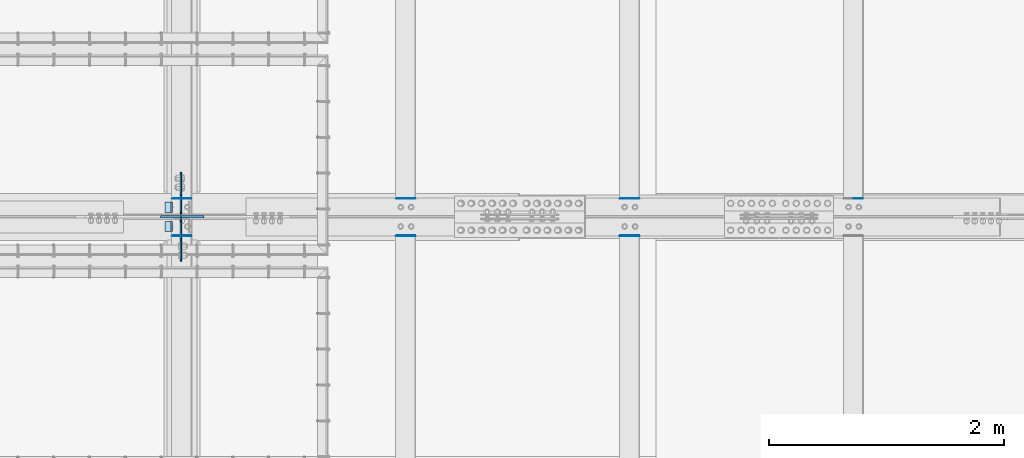
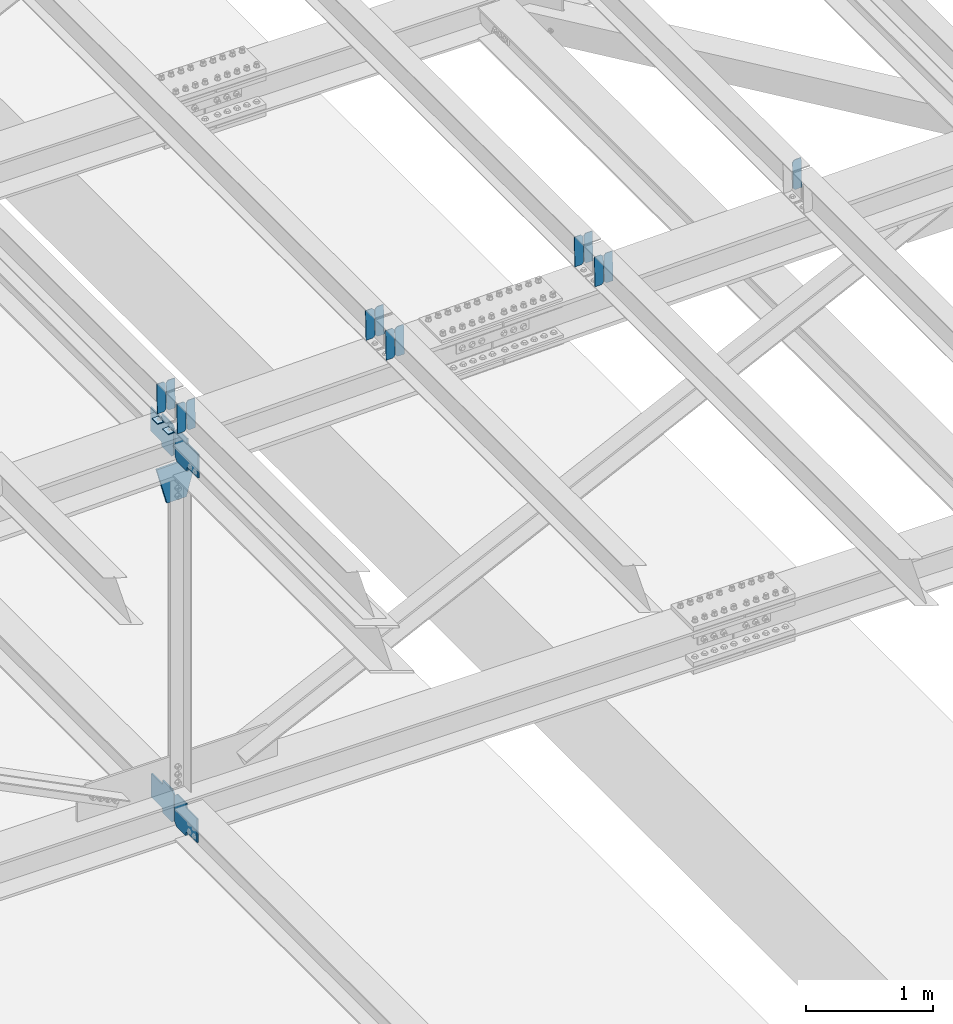
# One storey, part 3317 of 3843: 20 plates, 9 elements without a shape of their own.
"""IFC2X3 building model written with IfcOpenShell, lengths in millimetres."""

from ifc_helpers import new_model, si_unit, frame, origin_with_axes, place, context, subcontext, project, spatial, faceted_brep, material, type_object, element, aggregate, save


model = new_model("IFC2X3")

# Units and contexts
model_context = context("Model", 3, precision=1e-05, world=origin_with_axes())
body_context = subcontext(model_context, "Body", "Model", "MODEL_VIEW")
ifc_project = project(units=[si_unit("LENGTHUNIT", "METRE", prefix="MILLI"), si_unit("AREAUNIT", "SQUARE_METRE"), si_unit("VOLUMEUNIT", "CUBIC_METRE"), si_unit("MASSUNIT", "GRAM", prefix="KILO"), si_unit("TIMEUNIT", "SECOND"), si_unit("PLANEANGLEUNIT", "RADIAN"), si_unit("SOLIDANGLEUNIT", "STERADIAN"), si_unit("THERMODYNAMICTEMPERATUREUNIT", "DEGREE_CELSIUS"), si_unit("LUMINOUSINTENSITYUNIT", "LUMEN")], contexts=[model_context])

# Site, building, storey
site_placement = place(None, origin_with_axes())
site = spatial("IfcSite", under=ifc_project, at=site_placement, CompositionType="ELEMENT")
building_placement = place(site_placement, origin_with_axes())
building = spatial("IfcBuilding", under=site, at=building_placement, Name="Undefined", CompositionType="ELEMENT")
storey_placement = place(building_placement, origin_with_axes())
storey = spatial("IfcBuildingStorey", under=building, at=storey_placement, Name="Undefined", CompositionType="ELEMENT", Elevation=0.0)

# Assembly, plates
assembly_1_placement = place(storey_placement, origin_with_axes())
assembly_1 = element("IfcElementAssembly", 1, at=assembly_1_placement, inside=storey, Name="BEAM", AssemblyPlace="NOTDEFINED", PredefinedType="RIGID_FRAME")
ifc_material = material(Name="STEEL/A572-50")
plate_type_1 = type_object("IfcPlateType", PredefinedType="NOTDEFINED")
plate_1_placement = place(assembly_1_placement, frame((62718.6964783432, 59070.762745456, 46080.1519820071), z_axis=(-0.0211520975052917, 0.000376250999834155, 0.999776198559614), x_axis=(-0.9997762693548, -8.33599996866193e-06, -0.0211520960075009)))
plate_1 = element("IfcPlate", 2, at=plate_1_placement, type_object=plate_type_1, material=ifc_material, Name="PLATE", context=body_context, shape_type="Brep", body=[
    faceted_brep([(0.0, -3.17499999999927, 0.0), (6.83940015733242e-10, -3.17499999996653, 288.924999998613), (6.54836185276508e-10, 3.17500000001746, 288.924999998591), (0.0, 3.17499999999927, 0.0), (60.3250007643655, -3.17500000017753, 288.924999998606), (60.3250007643219, 3.17499999979918, 288.924999998584), (79.3750000013097, -3.17500000025029, 269.875000761494), (79.375000001266, 3.17499999972642, 269.875000761487), (79.375000000713, -3.17500000026484, 19.0499992370605), (79.3750000006985, 3.17499999971187, 19.0499992370533), (60.325000763667, -3.17500000020664, -1.45519152283669e-11), (60.3250007636234, 3.17499999977736, -3.63797880709171e-11)], [[[0, 1, 2, 3]], [[1, 4, 5, 2]], [[4, 6, 7, 5]], [[6, 8, 9, 7]], [[8, 10, 11, 9]], [[10, 0, 3, 11]], [[5, 7, 9, 11, 3, 2]], [[10, 8, 6, 4, 1, 0]]]),
])
plate_2_placement = place(assembly_1_placement, frame((62632.9906576536, 59070.7620630619, 46078.3387185351), z_axis=(-0.0211520975052917, 0.000376250999834155, 0.999776198559614), x_axis=(-0.9997762693548, -8.33599996866193e-06, -0.0211520960075009)))
plate_2 = element("IfcPlate", 3, at=plate_2_placement, type_object=plate_type_1, material=ifc_material, Name="PLATE", context=body_context, shape_type="Brep", body=[
    faceted_brep([(4.36557456851006e-11, -3.17499999998836, 19.0499992370969), (6.11180439591408e-10, -3.17499999996653, 269.875000761516), (5.96628524363041e-10, 3.17500000001746, 269.875000761502), (1.45519152283669e-11, 3.17499999998836, 19.0499992370824), (19.0499992376572, -3.17500000003201, 288.924999998606), (19.0499992376281, 3.1749999999447, 288.924999998584), (79.3750000013242, -3.17500000025029, 288.924999998591), (79.3750000013097, 3.1749999997337, 288.92499999857), (79.3750000006548, -3.17500000026484, -2.18278728425503e-11), (79.3750000006403, 3.17499999969732, -2.91038304567337e-11), (19.0499992370023, -3.17500000005384, 0.0), (19.0499992369587, 3.17499999992287, -1.45519152283669e-11)], [[[0, 1, 2, 3]], [[1, 4, 5, 2]], [[4, 6, 7, 5]], [[6, 8, 9, 7]], [[8, 10, 11, 9]], [[10, 0, 3, 11]], [[5, 7, 9, 11, 3, 2]], [[10, 8, 6, 4, 1, 0]]]),
])

assembly_2_placement = place(storey_placement, origin_with_axes())
assembly_2 = element("IfcElementAssembly", 4, at=assembly_2_placement, inside=storey, Name="BEAM", AssemblyPlace="NOTDEFINED", PredefinedType="RIGID_FRAME")
plate_3_placement = place(assembly_2_placement, frame((62718.6964783118, 58753.4858396267, 46080.1503629439), z_axis=(-0.0211520984675226, -0.000371508000112954, 0.999776200312963), x_axis=(-0.999776269354799, 8.33600001439919e-06, -0.0211520960075334)))
plate_3 = element("IfcPlate", 5, at=plate_3_placement, type_object=plate_type_1, material=ifc_material, Name="PLATE", context=body_context, shape_type="Brep", body=[
    faceted_brep([(0.0, -3.17499999999927, 0.0), (6.83940015733242e-10, -3.17499999996653, 288.924999998613), (6.54836185276508e-10, 3.17500000001746, 288.924999998591), (0.0, 3.17499999999927, 0.0), (60.3250007643655, -3.17500000017753, 288.924999998606), (60.3250007643219, 3.17499999979918, 288.924999998584), (79.3750000013097, -3.17500000025029, 269.875000761494), (79.375000001266, 3.17499999972642, 269.875000761487), (79.375000000713, -3.17500000026484, 19.0499992370605), (79.3750000006985, 3.17499999971187, 19.0499992370533), (60.325000763667, -3.17500000020664, -1.45519152283669e-11), (60.3250007636234, 3.17499999977736, -3.63797880709171e-11)], [[[0, 1, 2, 3]], [[1, 4, 5, 2]], [[4, 6, 7, 5]], [[6, 8, 9, 7]], [[8, 10, 11, 9]], [[10, 0, 3, 11]], [[5, 7, 9, 11, 3, 2]], [[10, 8, 6, 4, 1, 0]]]),
])
plate_4_placement = place(assembly_2_placement, frame((62632.9906576221, 58753.4865134214, 46078.3370994677), z_axis=(-0.0211520984675226, -0.000371508000112954, 0.999776200312963), x_axis=(-0.999776269354799, 8.33600001439919e-06, -0.0211520960075334)))
plate_4 = element("IfcPlate", 6, at=plate_4_placement, type_object=plate_type_1, material=ifc_material, Name="PLATE", context=body_context, shape_type="Brep", body=[
    faceted_brep([(4.36557456851006e-11, -3.17499999998836, 19.0499992370969), (6.11180439591408e-10, -3.17499999996653, 269.875000761516), (5.96628524363041e-10, 3.17500000001746, 269.875000761502), (1.45519152283669e-11, 3.17499999998836, 19.0499992370824), (19.0499992376572, -3.17500000003201, 288.924999998606), (19.0499992376281, 3.1749999999447, 288.924999998584), (79.3750000013242, -3.17500000025029, 288.924999998591), (79.3750000013097, 3.1749999997337, 288.92499999857), (79.3750000006548, -3.17500000026484, -2.18278728425503e-11), (79.3750000006403, 3.17499999969732, -2.91038304567337e-11), (19.0499992370023, -3.17500000005384, 0.0), (19.0499992369587, 3.17499999992287, -1.45519152283669e-11)], [[[0, 1, 2, 3]], [[1, 4, 5, 2]], [[4, 6, 7, 5]], [[6, 8, 9, 7]], [[8, 10, 11, 9]], [[10, 0, 3, 11]], [[5, 7, 9, 11, 3, 2]], [[10, 8, 6, 4, 1, 0]]]),
])

# Assembly, plate
assembly_3_placement = place(storey_placement, origin_with_axes())
assembly_3 = element("IfcElementAssembly", 7, at=assembly_3_placement, inside=storey, Name="BEAM", AssemblyPlace="NOTDEFINED", PredefinedType="RIGID_FRAME")
plate_5_placement = place(assembly_3_placement, frame((68433.6964817623, 59070.741525051, 46205.0688517431), z_axis=(-0.0211520981150825, 0.000447354000119958, 0.999776169259764), x_axis=(-0.999776269336729, -1.02780000340977e-05, -0.0211520960071139)))
plate_5 = element("IfcPlate", 8, at=plate_5_placement, type_object=plate_type_1, material=ifc_material, Name="PLATE", context=body_context, shape_type="Brep", body=[
    faceted_brep([(0.0, -3.17499999999927, 0.0), (6.83940015733242e-10, -3.17499999996653, 288.924999998613), (6.54836185276508e-10, 3.17500000001746, 288.924999998591), (0.0, 3.17499999999927, 0.0), (60.3250007643655, -3.17500000017753, 288.924999998606), (60.3250007643219, 3.17499999979918, 288.924999998584), (79.3750000013097, -3.17500000025029, 269.875000761494), (79.375000001266, 3.17499999972642, 269.875000761487), (79.375000000713, -3.17500000026484, 19.0499992370605), (79.3750000006985, 3.17499999971187, 19.0499992370533), (60.325000763667, -3.17500000020664, -1.45519152283669e-11), (60.3250007636234, 3.17499999977736, -3.63797880709171e-11)], [[[0, 1, 2, 3]], [[1, 4, 5, 2]], [[4, 6, 7, 5]], [[6, 8, 9, 7]], [[8, 10, 11, 9]], [[10, 0, 3, 11]], [[5, 7, 9, 11, 3, 2]], [[10, 8, 6, 4, 1, 0]]]),
])
aggregate(assembly_3, [plate_5])

# Assembly, plates
assembly_4_placement = place(storey_placement, origin_with_axes())
assembly_4 = element("IfcElementAssembly", 9, at=assembly_4_placement, inside=storey, Name="BEAM", AssemblyPlace="NOTDEFINED", PredefinedType="RIGID_FRAME")
plate_6_placement = place(assembly_4_placement, frame((66528.6964817708, 59070.7498081989, 46164.0919429248), z_axis=(-0.0211520978608897, 0.000419598000124098, 0.999776181299395), x_axis=(-0.9997762693548, -8.33599996866193e-06, -0.0211520960075009)))
plate_6 = element("IfcPlate", 10, at=plate_6_placement, type_object=plate_type_1, material=ifc_material, Name="PLATE", context=body_context, shape_type="Brep", body=[
    faceted_brep([(0.0, -3.17499999999927, 0.0), (6.83940015733242e-10, -3.17499999996653, 288.924999998613), (6.54836185276508e-10, 3.17500000001746, 288.924999998591), (0.0, 3.17499999999927, 0.0), (60.3250007643655, -3.17500000017753, 288.924999998606), (60.3250007643219, 3.17499999979918, 288.924999998584), (79.3750000013097, -3.17500000025029, 269.875000761494), (79.375000001266, 3.17499999972642, 269.875000761487), (79.375000000713, -3.17500000026484, 19.0499992370605), (79.3750000006985, 3.17499999971187, 19.0499992370533), (60.325000763667, -3.17500000020664, -1.45519152283669e-11), (60.3250007636234, 3.17499999977736, -3.63797880709171e-11)], [[[0, 1, 2, 3]], [[1, 4, 5, 2]], [[4, 6, 7, 5]], [[6, 8, 9, 7]], [[8, 10, 11, 9]], [[10, 0, 3, 11]], [[5, 7, 9, 11, 3, 2]], [[10, 8, 6, 4, 1, 0]]]),
])
plate_7_placement = place(assembly_4_placement, frame((66442.9906610805, 59070.7490490722, 46162.2786794823), z_axis=(-0.0211520978608897, 0.000419598000124098, 0.999776181299395), x_axis=(-0.9997762693548, -8.33599996866193e-06, -0.0211520960075009)))
plate_7 = element("IfcPlate", 11, at=plate_7_placement, type_object=plate_type_1, material=ifc_material, Name="PLATE", context=body_context, shape_type="Brep", body=[
    faceted_brep([(4.36557456851006e-11, -3.17499999998836, 19.0499992370969), (6.11180439591408e-10, -3.17499999996653, 269.875000761516), (5.96628524363041e-10, 3.17500000001746, 269.875000761502), (1.45519152283669e-11, 3.17499999998836, 19.0499992370824), (19.0499992376572, -3.17500000003201, 288.924999998606), (19.0499992376281, 3.1749999999447, 288.924999998584), (79.3750000013242, -3.17500000025029, 288.924999998591), (79.3750000013097, 3.1749999997337, 288.92499999857), (79.3750000006548, -3.17500000026484, -2.18278728425503e-11), (79.3750000006403, 3.17499999969732, -2.91038304567337e-11), (19.0499992370023, -3.17500000005384, 0.0), (19.0499992369587, 3.17499999992287, -1.45519152283669e-11)], [[[0, 1, 2, 3]], [[1, 4, 5, 2]], [[4, 6, 7, 5]], [[6, 8, 9, 7]], [[8, 10, 11, 9]], [[10, 0, 3, 11]], [[5, 7, 9, 11, 3, 2]], [[10, 8, 6, 4, 1, 0]]]),
])
aggregate(assembly_4, [plate_6, plate_7])

assembly_5_placement = place(storey_placement, origin_with_axes())
assembly_5 = element("IfcElementAssembly", 12, at=assembly_5_placement, inside=storey, Name="BEAM", AssemblyPlace="NOTDEFINED", PredefinedType="RIGID_FRAME")
plate_8_placement = place(assembly_5_placement, frame((66528.6964783558, 58753.5020115444, 46164.0882872405), z_axis=(-0.0211520979246561, -0.000425699999883364, 0.999776178718465), x_axis=(-0.999776269351943, 8.67199997865676e-06, -0.0211520960074328)))
plate_8 = element("IfcPlate", 13, at=plate_8_placement, type_object=plate_type_1, material=ifc_material, Name="PLATE", context=body_context, shape_type="Brep", body=[
    faceted_brep([(0.0, -3.17499999999927, 0.0), (6.83940015733242e-10, -3.17499999996653, 288.924999998613), (6.54836185276508e-10, 3.17500000001746, 288.924999998591), (0.0, 3.17499999999927, 0.0), (60.3250007643655, -3.17500000017753, 288.924999998606), (60.3250007643219, 3.17499999979918, 288.924999998584), (79.3750000013097, -3.17500000025029, 269.875000761494), (79.375000001266, 3.17499999972642, 269.875000761487), (79.375000000713, -3.17500000026484, 19.0499992370605), (79.3750000006985, 3.17499999971187, 19.0499992370533), (60.325000763667, -3.17500000020664, -1.45519152283669e-11), (60.3250007636234, 3.17499999977736, -3.63797880709171e-11)], [[[0, 1, 2, 3]], [[1, 4, 5, 2]], [[4, 6, 7, 5]], [[6, 8, 9, 7]], [[8, 10, 11, 9]], [[10, 0, 3, 11]], [[5, 7, 9, 11, 3, 2]], [[10, 8, 6, 4, 1, 0]]]),
])
plate_9_placement = place(assembly_5_placement, frame((66442.9906576646, 58753.5027836236, 46162.2750238046), z_axis=(-0.0211520979246561, -0.000425699999883364, 0.999776178718465), x_axis=(-0.999776269351943, 8.67199997865676e-06, -0.0211520960074328)))
plate_9 = element("IfcPlate", 14, at=plate_9_placement, type_object=plate_type_1, material=ifc_material, Name="PLATE", context=body_context, shape_type="Brep", body=[
    faceted_brep([(4.36557456851006e-11, -3.17499999998836, 19.0499992370969), (6.11180439591408e-10, -3.17499999996653, 269.875000761516), (5.96628524363041e-10, 3.17500000001746, 269.875000761502), (1.45519152283669e-11, 3.17499999998836, 19.0499992370824), (19.0499992376572, -3.17500000003201, 288.924999998606), (19.0499992376281, 3.1749999999447, 288.924999998584), (79.3750000013242, -3.17500000025029, 288.924999998591), (79.3750000013097, 3.1749999997337, 288.92499999857), (79.3750000006548, -3.17500000026484, -2.18278728425503e-11), (79.3750000006403, 3.17499999969732, -2.91038304567337e-11), (19.0499992370023, -3.17500000005384, 0.0), (19.0499992369587, 3.17499999992287, -1.45519152283669e-11)], [[[0, 1, 2, 3]], [[1, 4, 5, 2]], [[4, 6, 7, 5]], [[6, 8, 9, 7]], [[8, 10, 11, 9]], [[10, 0, 3, 11]], [[5, 7, 9, 11, 3, 2]], [[10, 8, 6, 4, 1, 0]]]),
])
aggregate(assembly_5, [plate_8, plate_9])

assembly_6_placement = place(storey_placement, origin_with_axes())
assembly_6 = element("IfcElementAssembly", 15, at=assembly_6_placement, inside=storey, Name="BEAM", AssemblyPlace="NOTDEFINED", PredefinedType="RIGID_FRAME")
plate_10_placement = place(assembly_6_placement, frame((64623.696481784, 59070.7559547485, 46122.481967059), z_axis=(-0.0211520976833125, 0.000399000999888811, 0.999776189735382), x_axis=(-0.9997762693548, -8.33599996866193e-06, -0.0211520960075009)))
plate_10 = element("IfcPlate", 16, at=plate_10_placement, type_object=plate_type_1, material=ifc_material, Name="PLATE", context=body_context, shape_type="Brep", body=[
    faceted_brep([(0.0, -3.17499999999927, 0.0), (6.83940015733242e-10, -3.17499999996653, 288.924999998613), (6.54836185276508e-10, 3.17500000001746, 288.924999998591), (0.0, 3.17499999999927, 0.0), (60.3250007643655, -3.17500000017753, 288.924999998606), (60.3250007643219, 3.17499999979918, 288.924999998584), (79.3750000013097, -3.17500000025029, 269.875000761494), (79.375000001266, 3.17499999972642, 269.875000761487), (79.375000000713, -3.17500000026484, 19.0499992370605), (79.3750000006985, 3.17499999971187, 19.0499992370533), (60.325000763667, -3.17500000020664, -1.45519152283669e-11), (60.3250007636234, 3.17499999977736, -3.63797880709171e-11)], [[[0, 1, 2, 3]], [[1, 4, 5, 2]], [[4, 6, 7, 5]], [[6, 8, 9, 7]], [[8, 10, 11, 9]], [[10, 0, 3, 11]], [[5, 7, 9, 11, 3, 2]], [[10, 8, 6, 4, 1, 0]]]),
])
plate_11_placement = place(assembly_6_placement, frame((64537.9906610943, 59070.7552329783, 46120.6687036018), z_axis=(-0.0211520976833125, 0.000399000999888811, 0.999776189735382), x_axis=(-0.9997762693548, -8.33599996866193e-06, -0.0211520960075009)))
plate_11 = element("IfcPlate", 17, at=plate_11_placement, type_object=plate_type_1, material=ifc_material, Name="PLATE", context=body_context, shape_type="Brep", body=[
    faceted_brep([(4.36557456851006e-11, -3.17499999998836, 19.0499992370969), (6.11180439591408e-10, -3.17499999996653, 269.875000761516), (5.96628524363041e-10, 3.17500000001746, 269.875000761502), (1.45519152283669e-11, 3.17499999998836, 19.0499992370824), (19.0499992376572, -3.17500000003201, 288.924999998606), (19.0499992376281, 3.1749999999447, 288.924999998584), (79.3750000013242, -3.17500000025029, 288.924999998591), (79.3750000013097, 3.1749999997337, 288.92499999857), (79.3750000006548, -3.17500000026484, -2.18278728425503e-11), (79.3750000006403, 3.17499999969732, -2.91038304567337e-11), (19.0499992370023, -3.17500000005384, 0.0), (19.0499992369587, 3.17499999992287, -1.45519152283669e-11)], [[[0, 1, 2, 3]], [[1, 4, 5, 2]], [[4, 6, 7, 5]], [[6, 8, 9, 7]], [[8, 10, 11, 9]], [[10, 0, 3, 11]], [[5, 7, 9, 11, 3, 2]], [[10, 8, 6, 4, 1, 0]]]),
])
aggregate(assembly_6, [plate_10, plate_11])

assembly_7_placement = place(storey_placement, origin_with_axes())
assembly_7 = element("IfcElementAssembly", 18, at=assembly_7_placement, inside=storey, Name="BEAM", AssemblyPlace="NOTDEFINED", PredefinedType="RIGID_FRAME")
plate_12_placement = place(assembly_7_placement, frame((64623.696478336, 58753.49392905, 46122.4794956833), z_axis=(-0.021152097688544, -0.000398615999954926, 0.999776189888847), x_axis=(-0.999776269351943, 8.67199997865676e-06, -0.0211520960074328)))
plate_12 = element("IfcPlate", 19, at=plate_12_placement, type_object=plate_type_1, material=ifc_material, Name="PLATE", context=body_context, shape_type="Brep", body=[
    faceted_brep([(0.0, -3.17499999999927, 0.0), (6.83940015733242e-10, -3.17499999996653, 288.924999998613), (6.54836185276508e-10, 3.17500000001746, 288.924999998591), (0.0, 3.17499999999927, 0.0), (60.3250007643655, -3.17500000017753, 288.924999998606), (60.3250007643219, 3.17499999979918, 288.924999998584), (79.3750000013097, -3.17500000025029, 269.875000761494), (79.375000001266, 3.17499999972642, 269.875000761487), (79.375000000713, -3.17500000026484, 19.0499992370605), (79.3750000006985, 3.17499999971187, 19.0499992370533), (60.325000763667, -3.17500000020664, -1.45519152283669e-11), (60.3250007636234, 3.17499999977736, -3.63797880709171e-11)], [[[0, 1, 2, 3]], [[1, 4, 5, 2]], [[4, 6, 7, 5]], [[6, 8, 9, 7]], [[8, 10, 11, 9]], [[10, 0, 3, 11]], [[5, 7, 9, 11, 3, 2]], [[10, 8, 6, 4, 1, 0]]]),
])
plate_13_placement = place(assembly_7_placement, frame((64537.9906576466, 58753.4946520073, 46120.6662322268), z_axis=(-0.021152097688544, -0.000398615999954926, 0.999776189888847), x_axis=(-0.999776269351943, 8.67199997865676e-06, -0.0211520960074328)))
plate_13 = element("IfcPlate", 20, at=plate_13_placement, type_object=plate_type_1, material=ifc_material, Name="PLATE", context=body_context, shape_type="Brep", body=[
    faceted_brep([(4.36557456851006e-11, -3.17499999998836, 19.0499992370969), (6.11180439591408e-10, -3.17499999996653, 269.875000761516), (5.96628524363041e-10, 3.17500000001746, 269.875000761502), (1.45519152283669e-11, 3.17499999998836, 19.0499992370824), (19.0499992376572, -3.17500000003201, 288.924999998606), (19.0499992376281, 3.1749999999447, 288.924999998584), (79.3750000013242, -3.17500000025029, 288.924999998591), (79.3750000013097, 3.1749999997337, 288.92499999857), (79.3750000006548, -3.17500000026484, -2.18278728425503e-11), (79.3750000006403, 3.17499999969732, -2.91038304567337e-11), (19.0499992370023, -3.17500000005384, 0.0), (19.0499992369587, 3.17499999992287, -1.45519152283669e-11)], [[[0, 1, 2, 3]], [[1, 4, 5, 2]], [[4, 6, 7, 5]], [[6, 8, 9, 7]], [[8, 10, 11, 9]], [[10, 0, 3, 11]], [[5, 7, 9, 11, 3, 2]], [[10, 8, 6, 4, 1, 0]]]),
])
aggregate(assembly_7, [plate_12, plate_13])

# Plate
plate_type_2 = type_object("IfcPlateType", PredefinedType="NOTDEFINED")
plate_14_placement = place(assembly_1_placement, frame((62553.767731786, 59042.3, 46070.3697076581), z_axis=(0.0, -1.0, 0.0), x_axis=(-0.999776270257024, 0.0, -0.0211520550054595)))
plate_14 = element("IfcPlate", 21, at=plate_14_placement, type_object=plate_type_2, material=ifc_material, Name="PLATE", context=body_context, shape_type="Brep", body=[
    faceted_brep([(9.52499999982683, -4.7625000001135, 88.8999999999942), (0.0, 4.76249999999709, 88.9000015258789), (0.0, 4.76249999999709, 0.0), (9.52499999981956, -4.76249999999709, 0.0), (63.4999984608512, -4.76249999988795, 88.8999999999796), (63.4999984608367, -4.76249999988795, -1.45519152283669e-11), (63.4999984608221, 4.76250000013533, -1.45519152283669e-11), (63.4999984608367, 4.76250000013533, 88.8999999999796)], [[[0, 1, 2, 3]], [[4, 5, 6, 7]], [[5, 4, 0, 3]], [[6, 5, 3, 2]], [[7, 6, 2, 1]], [[4, 7, 1, 0]]]),
])

aggregate(assembly_1, [plate_1, plate_2, plate_14])

plate_15_placement = place(assembly_2_placement, frame((62553.767731786, 58877.2000015258, 46070.3697076581), z_axis=(0.0, -1.0, 0.0), x_axis=(-0.999776270257024, 0.0, -0.0211520550054595)))
plate_15 = element("IfcPlate", 22, at=plate_15_placement, type_object=plate_type_2, material=ifc_material, Name="PLATE", context=body_context, shape_type="Brep", body=[
    faceted_brep([(9.52499999982683, -4.7625000001135, 88.8999999999942), (0.0, 4.76249999999709, 88.9000015258789), (0.0, 4.76249999999709, 0.0), (9.52499999981956, -4.76249999999709, 0.0), (63.4999984608512, -4.76249999988795, 88.8999999999796), (63.4999984608367, -4.76249999988795, -1.45519152283669e-11), (63.4999984608221, 4.76250000013533, -1.45519152283669e-11), (63.4999984608367, 4.76250000013533, 88.8999999999796)], [[[0, 1, 2, 3]], [[4, 5, 6, 7]], [[5, 4, 0, 3]], [[6, 5, 3, 2]], [[7, 6, 2, 1]], [[4, 7, 1, 0]]]),
])

aggregate(assembly_2, [plate_3, plate_4, plate_15])

# Assembly, plates
assembly_8_placement = place(storey_placement, origin_with_axes())
assembly_8 = element("IfcElementAssembly", 23, at=assembly_8_placement, inside=storey, Name="BEAM", AssemblyPlace="NOTDEFINED", PredefinedType="RIGID_FRAME")
plate_type_3 = type_object("IfcPlateType", PredefinedType="NOTDEFINED")
plate_16_placement = place(assembly_8_placement, frame((62625.2874999719, 58922.44375, 42217.0959217908), z_axis=(0.0, 0.707106781186548, 0.707106781186548), x_axis=(5.70000238222118e-08, 0.707106781186546, -0.707106781186546)))
plate_16 = element("IfcPlate", 24, at=plate_16_placement, type_object=plate_type_3, material=ifc_material, Name="PLATE", context=body_context, shape_type="Brep", body=[
    faceted_brep([(0.0, -6.3499999046162, 0.0), (-179.593979054845, -6.34999999999854, 179.593979055615), (-179.593979054845, 6.34999999999854, 179.593979055615), (7.27595761418343e-12, 6.3499999046162, 0.0), (-179.59397905474, -6.34999999999854, 224.49525966098), (-179.59397905474, 6.34999999999854, 224.49525966098), (-75.7597676884743, -6.34999999999854, 328.329471026809), (-75.7597676884743, 6.34999999999854, 328.329471026809), (-53.261477843118, -6.34999999999854, 305.831181181362), (-53.261477843118, 6.34999999999854, 305.831181181362), (-49.1413013749861, -6.34999999999854, 303.078167280881), (-49.1413013749861, 6.34999999999854, 303.078167280881), (-44.2812218569543, -6.34999999999854, 302.111437358297), (-44.2812218569543, 6.34999999999854, 302.111437358297), (-39.4211423389188, -6.34999999999854, 303.078167280866), (-39.4211423389188, 6.34999999999854, 303.078167280866), (-35.3009658707651, -6.34999999999854, 305.831181181318), (-35.3009658707651, 6.34999999999854, 305.831181181318), (81.4423638721655, -6.34999999999854, 422.574510923761), (81.4423638721655, 6.34999999999854, 422.574510923761), (243.086974051113, -6.34999999999854, 260.9299007441), (243.086974051113, 6.34999999999854, 260.9299007441), (126.343644308186, -6.34999999999854, 144.186571001686), (126.343644308186, 6.34999999999854, 144.186571001686), (123.590630407705, -6.34999999999854, 140.06639453354), (123.590630407705, 6.34999999999854, 140.06639453354), (122.623900485114, -6.34999999999854, 135.206315015515), (122.623900485114, 6.34999999999854, 135.206315015515), (123.590630407683, -6.34999999999854, 130.346235497462), (123.590630407683, 6.34999999999854, 130.346235497462), (126.34364430815, -6.34999999999854, 126.22605902933), (126.34364430815, 6.34999999999854, 126.22605902933), (148.735492004496, -6.35000000000582, 103.834211399357), (148.735492004496, 6.35000000000582, 103.834211399357), (44.9012806051323, -6.35000000000582, -1.45519152283669e-11), (44.9012806051323, 6.35000000000582, -1.45519152283669e-11)], [[[0, 1, 2, 3]], [[1, 4, 5, 2]], [[4, 6, 7, 5]], [[6, 8, 9, 7]], [[8, 10, 11, 9]], [[10, 12, 13, 11]], [[12, 14, 15, 13]], [[14, 16, 17, 15]], [[16, 18, 19, 17]], [[18, 20, 21, 19]], [[20, 22, 23, 21]], [[22, 24, 25, 23]], [[24, 26, 27, 25]], [[26, 28, 29, 27]], [[28, 30, 31, 29]], [[30, 32, 33, 31]], [[32, 34, 35, 33]], [[34, 0, 3, 35]], [[5, 7, 9, 11, 13, 15, 17, 19, 21, 23, 25, 27, 29, 31, 33, 35, 3, 2]], [[34, 32, 30, 28, 26, 24, 22, 20, 18, 16, 14, 12, 10, 8, 6, 4, 1, 0]]]),
])
plate_17_placement = place(assembly_8_placement, frame((62625.2874999137, 58908.1562499539, 42217.0959216253), z_axis=(0.0, -0.707106781186682, 0.707106781186413), x_axis=(0.0, -0.707106781186548, -0.707106781186548)))
plate_17 = element("IfcPlate", 25, at=plate_17_placement, type_object=plate_type_3, material=ifc_material, Name="PLATE", context=body_context, shape_type="Brep", body=[
    faceted_brep([(0.0, -6.3499999046162, 0.0), (-179.593979054845, -6.34999999999854, 179.593979055615), (-179.593979054845, 6.34999999999854, 179.593979055615), (7.27595761418343e-12, 6.3499999046162, 0.0), (-179.59397905474, -6.34999999999854, 224.49525966098), (-179.59397905474, 6.34999999999854, 224.49525966098), (-75.7597676884743, -6.34999999999854, 328.329471026809), (-75.7597676884743, 6.34999999999854, 328.329471026809), (-53.261477843118, -6.34999999999854, 305.831181181362), (-53.261477843118, 6.34999999999854, 305.831181181362), (-49.1413013749861, -6.34999999999854, 303.078167280881), (-49.1413013749861, 6.34999999999854, 303.078167280881), (-44.2812218569543, -6.34999999999854, 302.111437358297), (-44.2812218569543, 6.34999999999854, 302.111437358297), (-39.4211423389188, -6.34999999999854, 303.078167280866), (-39.4211423389188, 6.34999999999854, 303.078167280866), (-35.3009658707651, -6.34999999999854, 305.831181181318), (-35.3009658707651, 6.34999999999854, 305.831181181318), (81.4423638721655, -6.34999999999854, 422.574510923761), (81.4423638721655, 6.34999999999854, 422.574510923761), (243.086974051113, -6.34999999999854, 260.9299007441), (243.086974051113, 6.34999999999854, 260.9299007441), (126.343644308186, -6.34999999999854, 144.186571001686), (126.343644308186, 6.34999999999854, 144.186571001686), (123.590630407705, -6.34999999999854, 140.06639453354), (123.590630407705, 6.34999999999854, 140.06639453354), (122.623900485114, -6.34999999999854, 135.206315015515), (122.623900485114, 6.34999999999854, 135.206315015515), (123.590630407683, -6.34999999999854, 130.346235497462), (123.590630407683, 6.34999999999854, 130.346235497462), (126.34364430815, -6.34999999999854, 126.22605902933), (126.34364430815, 6.34999999999854, 126.22605902933), (148.735492004496, -6.35000000000582, 103.834211399357), (148.735492004496, 6.35000000000582, 103.834211399357), (44.9012806051323, -6.35000000000582, -1.45519152283669e-11), (44.9012806051323, 6.35000000000582, -1.45519152283669e-11)], [[[0, 1, 2, 3]], [[1, 4, 5, 2]], [[4, 6, 7, 5]], [[6, 8, 9, 7]], [[8, 10, 11, 9]], [[10, 12, 13, 11]], [[12, 14, 15, 13]], [[14, 16, 17, 15]], [[16, 18, 19, 17]], [[18, 20, 21, 19]], [[20, 22, 23, 21]], [[22, 24, 25, 23]], [[24, 26, 27, 25]], [[26, 28, 29, 27]], [[28, 30, 31, 29]], [[30, 32, 33, 31]], [[32, 34, 35, 33]], [[34, 0, 3, 35]], [[5, 7, 9, 11, 13, 15, 17, 19, 21, 23, 25, 27, 29, 31, 33, 35, 3, 2]], [[34, 32, 30, 28, 26, 24, 22, 20, 18, 16, 14, 12, 10, 8, 6, 4, 1, 0]]]),
])
aggregate(assembly_8, [plate_16, plate_17])

assembly_9_placement = place(storey_placement, origin_with_axes())
assembly_9 = element("IfcElementAssembly", 26, at=assembly_9_placement, inside=storey, Name="BEAM", AssemblyPlace="NOTDEFINED", PredefinedType="RIGID_FRAME")
plate_18_placement = place(assembly_9_placement, frame((62625.2875706102, 58904.1874999761, 45743.3058053167), z_axis=(0.0, -0.707106781186682, 0.707106781186413), x_axis=(0.0, -0.707106781186548, -0.707106781186548)))
plate_18 = element("IfcPlate", 27, at=plate_18_placement, type_object=plate_type_3, material=ifc_material, Name="PLATE", context=body_context, shape_type="Brep", body=[
    faceted_brep([(0.0, -6.3499999046162, 0.0), (-179.46135401944, -6.34999999999854, 179.461354019426), (-179.46135401944, 6.34999999999854, 179.461354019426), (7.27595761418343e-12, 6.3499999046162, 0.0), (-179.46135401944, -6.34999999999854, 224.362634624547), (-179.46135401944, 6.34999999999854, 224.362634624547), (-68.3306845217012, -6.34999999999854, 335.493304122276), (-68.3306845217012, 6.34999999999854, 335.493304122276), (-46.0609409098106, -6.34999999999854, 313.223560510382), (-46.0609409098106, 6.34999999999854, 313.223560510382), (-41.9407644416642, -6.34999999999854, 310.470546609904), (-41.9407644416642, 6.34999999999854, 310.470546609904), (-37.0806849236396, -6.34999999999854, 309.503816687327), (-37.0806849236396, 6.34999999999854, 309.503816687327), (-32.2206054056005, -6.34999999999854, 310.470546609904), (-32.2206054056005, 6.34999999999854, 310.470546609904), (-28.1004289374541, -6.34999999999854, 313.223560510382), (-28.1004289374541, 6.34999999999854, 313.223560510382), (88.6429007707047, -6.34999999999854, 429.966890218533), (88.6429007707047, 6.34999999999854, 429.966890218533), (250.287510949172, -6.34999999999854, 268.322280040062), (250.287510949172, 6.34999999999854, 268.322280040062), (133.544181241014, -6.34999999999854, 151.578950331921), (133.544181241014, 6.34999999999854, 151.578950331921), (130.791167340532, -6.34999999999854, 147.458773863775), (130.791167340532, 6.34999999999854, 147.458773863775), (129.824437417949, -6.34999999999854, 142.598694345743), (129.824437417949, 6.34999999999854, 142.598694345743), (130.791167340532, -6.34999999999854, 137.738614827711), (130.791167340532, 6.34999999999854, 137.738614827711), (133.544181241014, -6.34999999999854, 133.618438359565), (133.544181241014, 6.34999999999854, 133.618438359565), (156.031950102829, -6.35000000000582, 111.130669497703), (156.031950102829, 6.35000000000582, 111.130669497703), (44.9012806051323, -6.35000000000582, -1.45519152283669e-11), (44.9012806051323, 6.35000000000582, -1.45519152283669e-11)], [[[0, 1, 2, 3]], [[1, 4, 5, 2]], [[4, 6, 7, 5]], [[6, 8, 9, 7]], [[8, 10, 11, 9]], [[10, 12, 13, 11]], [[12, 14, 15, 13]], [[14, 16, 17, 15]], [[16, 18, 19, 17]], [[18, 20, 21, 19]], [[20, 22, 23, 21]], [[22, 24, 25, 23]], [[24, 26, 27, 25]], [[26, 28, 29, 27]], [[28, 30, 31, 29]], [[30, 32, 33, 31]], [[32, 34, 35, 33]], [[34, 0, 3, 35]], [[5, 7, 9, 11, 13, 15, 17, 19, 21, 23, 25, 27, 29, 31, 33, 35, 3, 2]], [[34, 32, 30, 28, 26, 24, 22, 20, 18, 16, 14, 12, 10, 8, 6, 4, 1, 0]]]),
])
plate_19_placement = place(assembly_9_placement, frame((62625.2874997979, 58926.4125, 45743.3058035531), z_axis=(0.0, 0.707106781186548, 0.707106781186548), x_axis=(5.70000238222118e-08, 0.707106781186546, -0.707106781186546)))
plate_19 = element("IfcPlate", 28, at=plate_19_placement, type_object=plate_type_3, material=ifc_material, Name="PLATE", context=body_context, shape_type="Brep", body=[
    faceted_brep([(0.0, -6.3499999046162, 0.0), (-179.46135401944, -6.34999999999854, 179.461354019426), (-179.46135401944, 6.34999999999854, 179.461354019426), (7.27595761418343e-12, 6.3499999046162, 0.0), (-179.46135401944, -6.34999999999854, 224.362634624547), (-179.46135401944, 6.34999999999854, 224.362634624547), (-68.3306845217012, -6.34999999999854, 335.493304122276), (-68.3306845217012, 6.34999999999854, 335.493304122276), (-46.0609409098106, -6.34999999999854, 313.223560510382), (-46.0609409098106, 6.34999999999854, 313.223560510382), (-41.9407644416642, -6.34999999999854, 310.470546609904), (-41.9407644416642, 6.34999999999854, 310.470546609904), (-37.0806849236396, -6.34999999999854, 309.503816687327), (-37.0806849236396, 6.34999999999854, 309.503816687327), (-32.2206054056005, -6.34999999999854, 310.470546609904), (-32.2206054056005, 6.34999999999854, 310.470546609904), (-28.1004289374541, -6.34999999999854, 313.223560510382), (-28.1004289374541, 6.34999999999854, 313.223560510382), (88.6429007707047, -6.34999999999854, 429.966890218533), (88.6429007707047, 6.34999999999854, 429.966890218533), (250.287510949172, -6.34999999999854, 268.322280040062), (250.287510949172, 6.34999999999854, 268.322280040062), (133.544181241014, -6.34999999999854, 151.578950331921), (133.544181241014, 6.34999999999854, 151.578950331921), (130.791167340532, -6.34999999999854, 147.458773863775), (130.791167340532, 6.34999999999854, 147.458773863775), (129.824437417949, -6.34999999999854, 142.598694345743), (129.824437417949, 6.34999999999854, 142.598694345743), (130.791167340532, -6.34999999999854, 137.738614827711), (130.791167340532, 6.34999999999854, 137.738614827711), (133.544181241014, -6.34999999999854, 133.618438359565), (133.544181241014, 6.34999999999854, 133.618438359565), (156.031950102829, -6.35000000000582, 111.130669497703), (156.031950102829, 6.35000000000582, 111.130669497703), (44.9012806051323, -6.35000000000582, -1.45519152283669e-11), (44.9012806051323, 6.35000000000582, -1.45519152283669e-11)], [[[0, 1, 2, 3]], [[1, 4, 5, 2]], [[4, 6, 7, 5]], [[6, 8, 9, 7]], [[8, 10, 11, 9]], [[10, 12, 13, 11]], [[12, 14, 15, 13]], [[14, 16, 17, 15]], [[16, 18, 19, 17]], [[18, 20, 21, 19]], [[20, 22, 23, 21]], [[22, 24, 25, 23]], [[24, 26, 27, 25]], [[26, 28, 29, 27]], [[28, 30, 31, 29]], [[30, 32, 33, 31]], [[32, 34, 35, 33]], [[34, 0, 3, 35]], [[5, 7, 9, 11, 13, 15, 17, 19, 21, 23, 25, 27, 29, 31, 33, 35, 3, 2]], [[34, 32, 30, 28, 26, 24, 22, 20, 18, 16, 14, 12, 10, 8, 6, 4, 1, 0]]]),
])
plate_type_4 = type_object("IfcPlateType", PredefinedType="NOTDEFINED")
plate_20_placement = place(assembly_9_placement, frame((62821.6355780112, 58915.3, 45676.9259105983), z_axis=(0.0224149339956129, 0.0, -0.999748753804661), x_axis=(-0.999748753804661, 0.0, -0.0224149339956119)))
plate_20 = element("IfcPlate", 29, at=plate_20_placement, type_object=plate_type_4, material=ifc_material, Name="PLATE", context=body_context, shape_type="Brep", body=[
    faceted_brep([(0.0, -9.52500000000146, 0.0), (104.389475907206, -9.52500000000146, 358.139374506914), (104.389475907206, 9.52500000000146, 358.139374506914), (0.0, 9.52500000000146, 0.0), (282.144805327538, -9.52500000000146, 354.153999222232), (282.144805327538, 9.52500000000146, 354.153999222232), (368.386744569085, -9.52500000000146, 1.33150024339557e-09), (368.386744569085, 9.52500000000146, 1.33150024339557e-09)], [[[0, 1, 2, 3]], [[1, 4, 5, 2]], [[4, 6, 7, 5]], [[6, 0, 3, 7]], [[5, 7, 3, 2]], [[6, 4, 1, 0]]]),
])
aggregate(assembly_9, [plate_18, plate_19, plate_20])

save(model, "model.ifc")
